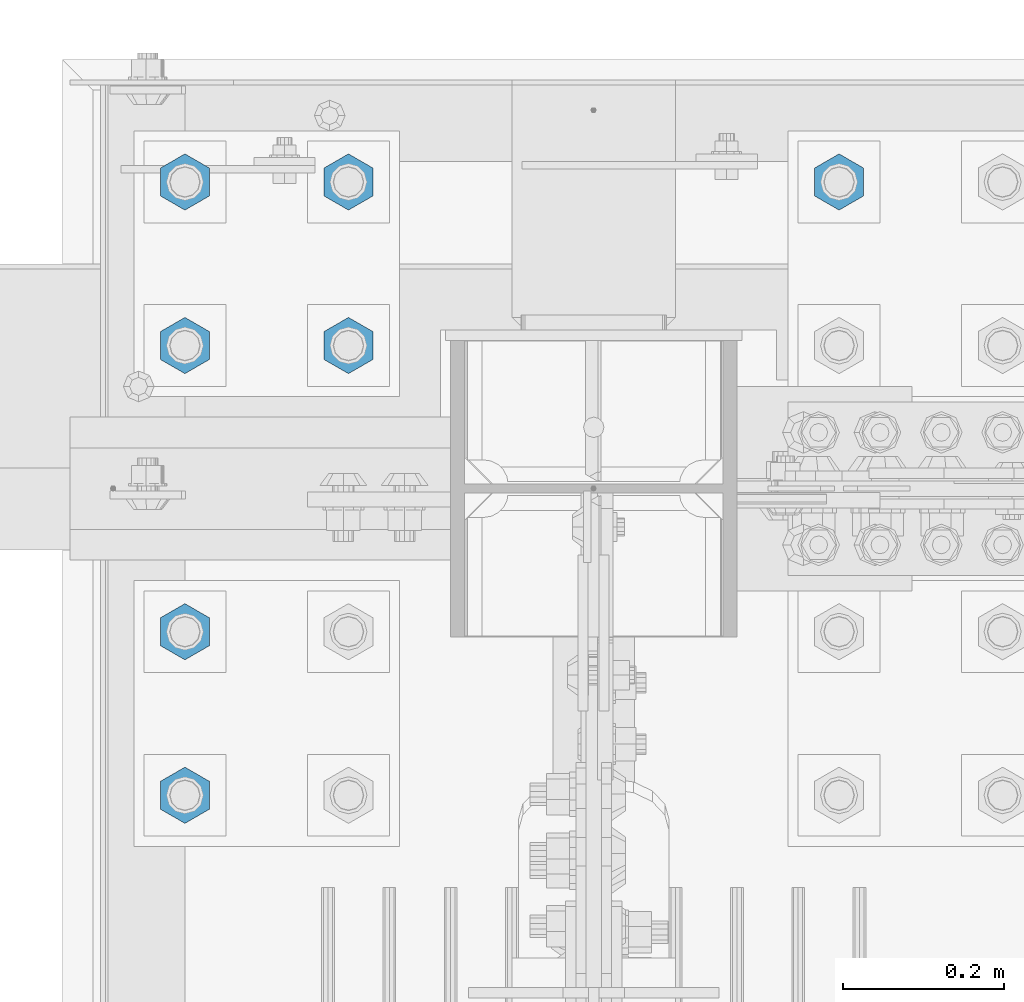
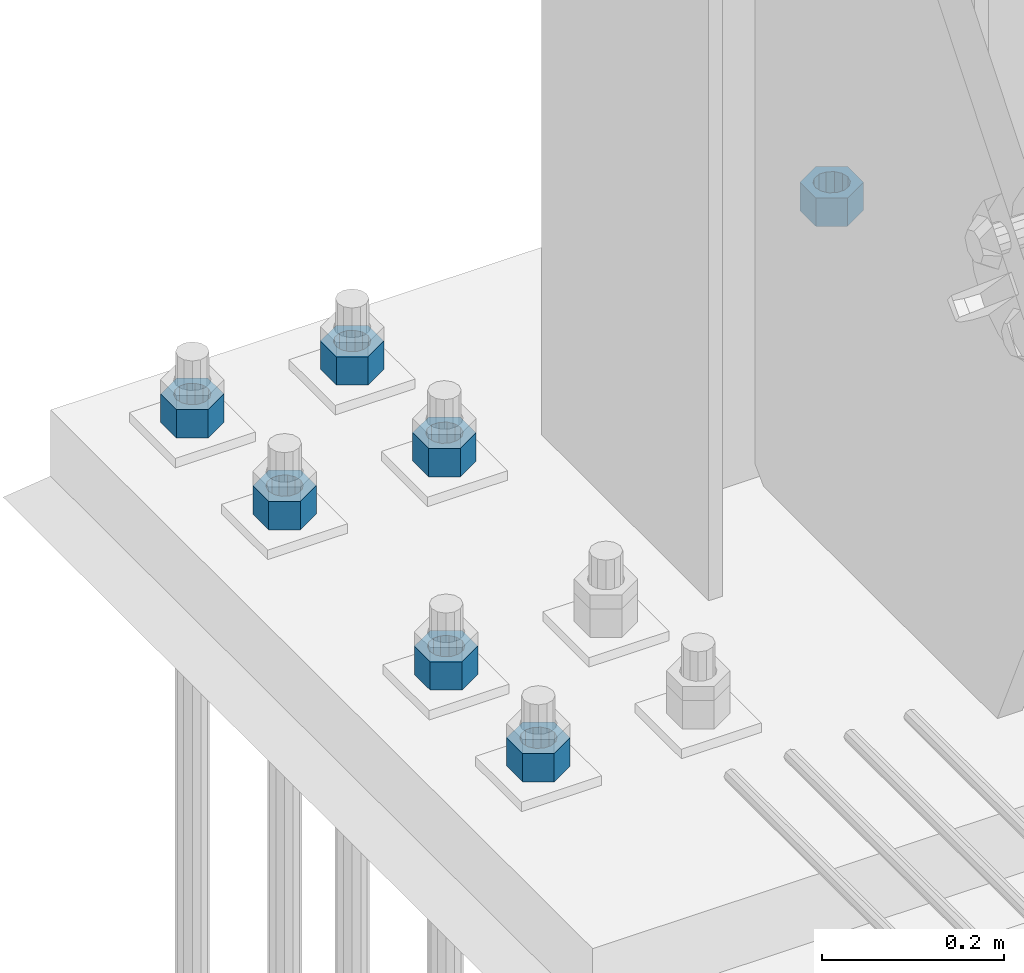
# One storey, part 1725 of 3843: 7 columns, 1 element without a shape of its own.
"""IFC2X3 building model written with IfcOpenShell, lengths in millimetres."""

from ifc_helpers import new_model, si_unit, frame, origin_with_axes, place, context, subcontext, project, spatial, faceted_brep, material, type_object, element, aggregate, save


model = new_model("IFC2X3")

# Units and contexts
model_context = context("Model", 3, precision=1e-05, world=origin_with_axes())
body_context = subcontext(model_context, "Body", "Model", "MODEL_VIEW")
ifc_project = project(units=[si_unit("LENGTHUNIT", "METRE", prefix="MILLI"), si_unit("AREAUNIT", "SQUARE_METRE"), si_unit("VOLUMEUNIT", "CUBIC_METRE"), si_unit("MASSUNIT", "GRAM", prefix="KILO"), si_unit("TIMEUNIT", "SECOND"), si_unit("PLANEANGLEUNIT", "RADIAN"), si_unit("SOLIDANGLEUNIT", "STERADIAN"), si_unit("THERMODYNAMICTEMPERATUREUNIT", "DEGREE_CELSIUS"), si_unit("LUMINOUSINTENSITYUNIT", "LUMEN")], contexts=[model_context])

# Site, building, storey
site_placement = place(None, origin_with_axes())
site = spatial("IfcSite", under=ifc_project, at=site_placement, CompositionType="ELEMENT")
building_placement = place(site_placement, origin_with_axes())
building = spatial("IfcBuilding", under=site, at=building_placement, Name="Undefined", CompositionType="ELEMENT")
storey_placement = place(building_placement, origin_with_axes())
storey = spatial("IfcBuildingStorey", under=building, at=storey_placement, Name="Undefined", CompositionType="ELEMENT", Elevation=0.0)

# Assembly, columns
assembly_placement = place(storey_placement, origin_with_axes())
assembly = element("IfcElementAssembly", 1, at=assembly_placement, inside=storey, Name="TEMPLATE", AssemblyPlace="NOTDEFINED", PredefinedType="RIGID_FRAME")
ifc_material = material(Name="STEEL/A572-50")
column_type = type_object("IfcColumnType", Name="1-1/2_HEAVY_HEX_NUT", PredefinedType="NOTDEFINED")
column_1_placement = place(assembly_placement, frame((77317.6, 104940.1, 29743.4), z_axis=(-1.0, 0.0, 0.0), x_axis=(0.0, 0.0, -1.0)))
column_1 = element("IfcColumn", 2, at=column_1_placement, type_object=column_type, material=ifc_material, Name="NUT", ObjectType="1-1/2_HEAVY_HEX_NUT", context=body_context, shape_type="Brep", body=[
    faceted_brep([(0.0, -34.9199981689453, 0.0), (0.0, -17.4599990844727, -30.25), (38.0999999999985, -17.4599990844727, -30.25), (38.0999999999985, -34.9199981689453, 0.0), (0.0, 17.4599990844727, -30.25), (38.0999999999985, 17.4599990844727, -30.25), (0.0, 34.9199981689453, 0.0), (38.0999999999985, 34.9199981689453, 0.0), (0.0, 17.4599990844727, 30.25), (38.0999999999985, 17.4599990844727, 30.25), (0.0, -17.4599990844727, 30.25), (38.0999999999985, -17.4599990844727, 30.25), (0.0, 0.0, 20.6399993896484), (0.0, 8.9553601105581, 18.5959968835959), (38.0999999999985, 8.9553601105581, 18.5959968835959), (38.0999999999985, 0.0, 20.6399993896484), (0.0, 16.1370013209525, 12.8688291298167), (38.0999999999985, 16.1370013209525, 12.8688291298167), (0.0, 20.1225115123816, 4.59283194104501), (38.0999999999985, 20.1225115123816, 4.59283194104501), (0.0, 20.1225115123816, -4.59283194104501), (38.0999999999985, 20.1225115123816, -4.59283194104501), (0.0, 16.1370013209525, -12.8688291298167), (38.0999999999985, 16.1370013209525, -12.8688291298167), (0.0, 8.9553601105581, -18.5959968835959), (38.0999999999985, 8.9553601105581, -18.5959968835959), (0.0, 0.0, -20.6399993896484), (38.0999999999985, 0.0, -20.6399993896484), (0.0, -8.9553601105581, -18.5959968835959), (38.0999999999985, -8.9553601105581, -18.5959968835959), (0.0, -16.1370013209525, -12.8688291298167), (38.0999999999985, -16.1370013209525, -12.8688291298167), (0.0, -20.1225115123816, -4.59283194104501), (38.0999999999985, -20.1225115123816, -4.59283194104501), (0.0, -20.1225115123816, 4.59283194104501), (38.0999999999985, -20.1225115123816, 4.59283194104501), (0.0, -16.1370013209525, 12.8688291298167), (38.0999999999985, -16.1370013209525, 12.8688291298167), (0.0, -8.9553601105581, 18.5959968835959), (38.0999999999985, -8.9553601105581, 18.5959968835959)], [[[0, 1, 2, 3]], [[1, 4, 5, 2]], [[4, 6, 7, 5]], [[6, 8, 9, 7]], [[8, 10, 11, 9]], [[10, 0, 3, 11]], [[12, 13, 14, 15]], [[13, 16, 17, 14]], [[16, 18, 19, 17]], [[18, 20, 21, 19]], [[20, 22, 23, 21]], [[22, 24, 25, 23]], [[24, 26, 27, 25]], [[26, 28, 29, 27]], [[28, 30, 31, 29]], [[30, 32, 33, 31]], [[32, 34, 35, 33]], [[34, 36, 37, 35]], [[36, 38, 39, 37]], [[38, 12, 15, 39]], [[5, 7, 9, 11, 3, 2], [17, 19, 21, 23, 25, 27, 29, 31, 33, 35, 37, 39, 15, 14]], [[10, 8, 6, 4, 1, 0], [38, 36, 34, 32, 30, 28, 26, 24, 22, 20, 18, 16, 13, 12]]]),
])
column_2_placement = place(assembly_placement, frame((76708.0, 104736.9, 29743.4), z_axis=(-1.0, 0.0, 0.0), x_axis=(0.0, 0.0, -1.0)))
column_2 = element("IfcColumn", 3, at=column_2_placement, type_object=column_type, material=ifc_material, Name="NUT", ObjectType="1-1/2_HEAVY_HEX_NUT", context=body_context, shape_type="Brep", body=[
    faceted_brep([(0.0, -34.9199981689453, 0.0), (0.0, -17.4599990844727, -30.25), (38.0999999999985, -17.4599990844727, -30.25), (38.0999999999985, -34.9199981689453, 0.0), (0.0, 17.4599990844727, -30.25), (38.0999999999985, 17.4599990844727, -30.25), (0.0, 34.9199981689453, 0.0), (38.0999999999985, 34.9199981689453, 0.0), (0.0, 17.4599990844727, 30.25), (38.0999999999985, 17.4599990844727, 30.25), (0.0, -17.4599990844727, 30.25), (38.0999999999985, -17.4599990844727, 30.25), (0.0, 0.0, 20.6399993896484), (0.0, 8.9553601105581, 18.5959968835959), (38.0999999999985, 8.9553601105581, 18.5959968835959), (38.0999999999985, 0.0, 20.6399993896484), (0.0, 16.1370013209525, 12.8688291298167), (38.0999999999985, 16.1370013209525, 12.8688291298167), (0.0, 20.1225115123816, 4.59283194104501), (38.0999999999985, 20.1225115123816, 4.59283194104501), (0.0, 20.1225115123816, -4.59283194104501), (38.0999999999985, 20.1225115123816, -4.59283194104501), (0.0, 16.1370013209525, -12.8688291298167), (38.0999999999985, 16.1370013209525, -12.8688291298167), (0.0, 8.9553601105581, -18.5959968835959), (38.0999999999985, 8.9553601105581, -18.5959968835959), (0.0, 0.0, -20.6399993896484), (38.0999999999985, 0.0, -20.6399993896484), (0.0, -8.9553601105581, -18.5959968835959), (38.0999999999985, -8.9553601105581, -18.5959968835959), (0.0, -16.1370013209525, -12.8688291298167), (38.0999999999985, -16.1370013209525, -12.8688291298167), (0.0, -20.1225115123816, -4.59283194104501), (38.0999999999985, -20.1225115123816, -4.59283194104501), (0.0, -20.1225115123816, 4.59283194104501), (38.0999999999985, -20.1225115123816, 4.59283194104501), (0.0, -16.1370013209525, 12.8688291298167), (38.0999999999985, -16.1370013209525, 12.8688291298167), (0.0, -8.9553601105581, 18.5959968835959), (38.0999999999985, -8.9553601105581, 18.5959968835959)], [[[0, 1, 2, 3]], [[1, 4, 5, 2]], [[4, 6, 7, 5]], [[6, 8, 9, 7]], [[8, 10, 11, 9]], [[10, 0, 3, 11]], [[12, 13, 14, 15]], [[13, 16, 17, 14]], [[16, 18, 19, 17]], [[18, 20, 21, 19]], [[20, 22, 23, 21]], [[22, 24, 25, 23]], [[24, 26, 27, 25]], [[26, 28, 29, 27]], [[28, 30, 31, 29]], [[30, 32, 33, 31]], [[32, 34, 35, 33]], [[34, 36, 37, 35]], [[36, 38, 39, 37]], [[38, 12, 15, 39]], [[5, 7, 9, 11, 3, 2], [17, 19, 21, 23, 25, 27, 29, 31, 33, 35, 37, 39, 15, 14]], [[10, 8, 6, 4, 1, 0], [38, 36, 34, 32, 30, 28, 26, 24, 22, 20, 18, 16, 13, 12]]]),
])
column_3_placement = place(assembly_placement, frame((76708.0, 104940.1, 29743.4), z_axis=(-1.0, 0.0, 0.0), x_axis=(0.0, 0.0, -1.0)))
column_3 = element("IfcColumn", 4, at=column_3_placement, type_object=column_type, material=ifc_material, Name="NUT", ObjectType="1-1/2_HEAVY_HEX_NUT", context=body_context, shape_type="Brep", body=[
    faceted_brep([(0.0, -34.9199981689453, 0.0), (0.0, -17.4599990844727, -30.25), (38.0999999999985, -17.4599990844727, -30.25), (38.0999999999985, -34.9199981689453, 0.0), (0.0, 17.4599990844727, -30.25), (38.0999999999985, 17.4599990844727, -30.25), (0.0, 34.9199981689453, 0.0), (38.0999999999985, 34.9199981689453, 0.0), (0.0, 17.4599990844727, 30.25), (38.0999999999985, 17.4599990844727, 30.25), (0.0, -17.4599990844727, 30.25), (38.0999999999985, -17.4599990844727, 30.25), (0.0, 0.0, 20.6399993896484), (0.0, 8.9553601105581, 18.5959968835959), (38.0999999999985, 8.9553601105581, 18.5959968835959), (38.0999999999985, 0.0, 20.6399993896484), (0.0, 16.1370013209525, 12.8688291298167), (38.0999999999985, 16.1370013209525, 12.8688291298167), (0.0, 20.1225115123816, 4.59283194104501), (38.0999999999985, 20.1225115123816, 4.59283194104501), (0.0, 20.1225115123816, -4.59283194104501), (38.0999999999985, 20.1225115123816, -4.59283194104501), (0.0, 16.1370013209525, -12.8688291298167), (38.0999999999985, 16.1370013209525, -12.8688291298167), (0.0, 8.9553601105581, -18.5959968835959), (38.0999999999985, 8.9553601105581, -18.5959968835959), (0.0, 0.0, -20.6399993896484), (38.0999999999985, 0.0, -20.6399993896484), (0.0, -8.9553601105581, -18.5959968835959), (38.0999999999985, -8.9553601105581, -18.5959968835959), (0.0, -16.1370013209525, -12.8688291298167), (38.0999999999985, -16.1370013209525, -12.8688291298167), (0.0, -20.1225115123816, -4.59283194104501), (38.0999999999985, -20.1225115123816, -4.59283194104501), (0.0, -20.1225115123816, 4.59283194104501), (38.0999999999985, -20.1225115123816, 4.59283194104501), (0.0, -16.1370013209525, 12.8688291298167), (38.0999999999985, -16.1370013209525, 12.8688291298167), (0.0, -8.9553601105581, 18.5959968835959), (38.0999999999985, -8.9553601105581, 18.5959968835959)], [[[0, 1, 2, 3]], [[1, 4, 5, 2]], [[4, 6, 7, 5]], [[6, 8, 9, 7]], [[8, 10, 11, 9]], [[10, 0, 3, 11]], [[12, 13, 14, 15]], [[13, 16, 17, 14]], [[16, 18, 19, 17]], [[18, 20, 21, 19]], [[20, 22, 23, 21]], [[22, 24, 25, 23]], [[24, 26, 27, 25]], [[26, 28, 29, 27]], [[28, 30, 31, 29]], [[30, 32, 33, 31]], [[32, 34, 35, 33]], [[34, 36, 37, 35]], [[36, 38, 39, 37]], [[38, 12, 15, 39]], [[5, 7, 9, 11, 3, 2], [17, 19, 21, 23, 25, 27, 29, 31, 33, 35, 37, 39, 15, 14]], [[10, 8, 6, 4, 1, 0], [38, 36, 34, 32, 30, 28, 26, 24, 22, 20, 18, 16, 13, 12]]]),
])
column_4_placement = place(assembly_placement, frame((76504.8, 104178.1, 29743.4), z_axis=(1.0, 0.0, 0.0), x_axis=(0.0, 0.0, -1.0)))
column_4 = element("IfcColumn", 5, at=column_4_placement, type_object=column_type, material=ifc_material, Name="NUT", ObjectType="1-1/2_HEAVY_HEX_NUT", context=body_context, shape_type="Brep", body=[
    faceted_brep([(0.0, -34.9199981689453, 0.0), (0.0, -17.4599990844727, -30.25), (38.0999999999985, -17.4599990844727, -30.25), (38.0999999999985, -34.9199981689453, 0.0), (0.0, 17.4599990844727, -30.25), (38.0999999999985, 17.4599990844727, -30.25), (0.0, 34.9199981689453, 0.0), (38.0999999999985, 34.9199981689453, 0.0), (0.0, 17.4599990844727, 30.25), (38.0999999999985, 17.4599990844727, 30.25), (0.0, -17.4599990844727, 30.25), (38.0999999999985, -17.4599990844727, 30.25), (0.0, 0.0, 20.6399993896484), (0.0, 8.9553601105581, 18.5959968835959), (38.0999999999985, 8.9553601105581, 18.5959968835959), (38.0999999999985, 0.0, 20.6399993896484), (0.0, 16.1370013209525, 12.8688291298167), (38.0999999999985, 16.1370013209525, 12.8688291298167), (0.0, 20.1225115123816, 4.59283194104501), (38.0999999999985, 20.1225115123816, 4.59283194104501), (0.0, 20.1225115123816, -4.59283194104501), (38.0999999999985, 20.1225115123816, -4.59283194104501), (0.0, 16.1370013209525, -12.8688291298167), (38.0999999999985, 16.1370013209525, -12.8688291298167), (0.0, 8.9553601105581, -18.5959968835959), (38.0999999999985, 8.9553601105581, -18.5959968835959), (0.0, 0.0, -20.6399993896484), (38.0999999999985, 0.0, -20.6399993896484), (0.0, -8.9553601105581, -18.5959968835959), (38.0999999999985, -8.9553601105581, -18.5959968835959), (0.0, -16.1370013209525, -12.8688291298167), (38.0999999999985, -16.1370013209525, -12.8688291298167), (0.0, -20.1225115123816, -4.59283194104501), (38.0999999999985, -20.1225115123816, -4.59283194104501), (0.0, -20.1225115123816, 4.59283194104501), (38.0999999999985, -20.1225115123816, 4.59283194104501), (0.0, -16.1370013209525, 12.8688291298167), (38.0999999999985, -16.1370013209525, 12.8688291298167), (0.0, -8.9553601105581, 18.5959968835959), (38.0999999999985, -8.9553601105581, 18.5959968835959)], [[[0, 1, 2, 3]], [[1, 4, 5, 2]], [[4, 6, 7, 5]], [[6, 8, 9, 7]], [[8, 10, 11, 9]], [[10, 0, 3, 11]], [[12, 13, 14, 15]], [[13, 16, 17, 14]], [[16, 18, 19, 17]], [[18, 20, 21, 19]], [[20, 22, 23, 21]], [[22, 24, 25, 23]], [[24, 26, 27, 25]], [[26, 28, 29, 27]], [[28, 30, 31, 29]], [[30, 32, 33, 31]], [[32, 34, 35, 33]], [[34, 36, 37, 35]], [[36, 38, 39, 37]], [[38, 12, 15, 39]], [[5, 7, 9, 11, 3, 2], [17, 19, 21, 23, 25, 27, 29, 31, 33, 35, 37, 39, 15, 14]], [[10, 8, 6, 4, 1, 0], [38, 36, 34, 32, 30, 28, 26, 24, 22, 20, 18, 16, 13, 12]]]),
])
column_5_placement = place(assembly_placement, frame((76504.8, 104381.3, 29743.4), z_axis=(1.0, 0.0, 0.0), x_axis=(0.0, 0.0, -1.0)))
column_5 = element("IfcColumn", 6, at=column_5_placement, type_object=column_type, material=ifc_material, Name="NUT", ObjectType="1-1/2_HEAVY_HEX_NUT", context=body_context, shape_type="Brep", body=[
    faceted_brep([(0.0, -34.9199981689453, 0.0), (0.0, -17.4599990844727, -30.25), (38.0999999999985, -17.4599990844727, -30.25), (38.0999999999985, -34.9199981689453, 0.0), (0.0, 17.4599990844727, -30.25), (38.0999999999985, 17.4599990844727, -30.25), (0.0, 34.9199981689453, 0.0), (38.0999999999985, 34.9199981689453, 0.0), (0.0, 17.4599990844727, 30.25), (38.0999999999985, 17.4599990844727, 30.25), (0.0, -17.4599990844727, 30.25), (38.0999999999985, -17.4599990844727, 30.25), (0.0, 0.0, 20.6399993896484), (0.0, 8.9553601105581, 18.5959968835959), (38.0999999999985, 8.9553601105581, 18.5959968835959), (38.0999999999985, 0.0, 20.6399993896484), (0.0, 16.1370013209525, 12.8688291298167), (38.0999999999985, 16.1370013209525, 12.8688291298167), (0.0, 20.1225115123816, 4.59283194104501), (38.0999999999985, 20.1225115123816, 4.59283194104501), (0.0, 20.1225115123816, -4.59283194104501), (38.0999999999985, 20.1225115123816, -4.59283194104501), (0.0, 16.1370013209525, -12.8688291298167), (38.0999999999985, 16.1370013209525, -12.8688291298167), (0.0, 8.9553601105581, -18.5959968835959), (38.0999999999985, 8.9553601105581, -18.5959968835959), (0.0, 0.0, -20.6399993896484), (38.0999999999985, 0.0, -20.6399993896484), (0.0, -8.9553601105581, -18.5959968835959), (38.0999999999985, -8.9553601105581, -18.5959968835959), (0.0, -16.1370013209525, -12.8688291298167), (38.0999999999985, -16.1370013209525, -12.8688291298167), (0.0, -20.1225115123816, -4.59283194104501), (38.0999999999985, -20.1225115123816, -4.59283194104501), (0.0, -20.1225115123816, 4.59283194104501), (38.0999999999985, -20.1225115123816, 4.59283194104501), (0.0, -16.1370013209525, 12.8688291298167), (38.0999999999985, -16.1370013209525, 12.8688291298167), (0.0, -8.9553601105581, 18.5959968835959), (38.0999999999985, -8.9553601105581, 18.5959968835959)], [[[0, 1, 2, 3]], [[1, 4, 5, 2]], [[4, 6, 7, 5]], [[6, 8, 9, 7]], [[8, 10, 11, 9]], [[10, 0, 3, 11]], [[12, 13, 14, 15]], [[13, 16, 17, 14]], [[16, 18, 19, 17]], [[18, 20, 21, 19]], [[20, 22, 23, 21]], [[22, 24, 25, 23]], [[24, 26, 27, 25]], [[26, 28, 29, 27]], [[28, 30, 31, 29]], [[30, 32, 33, 31]], [[32, 34, 35, 33]], [[34, 36, 37, 35]], [[36, 38, 39, 37]], [[38, 12, 15, 39]], [[5, 7, 9, 11, 3, 2], [17, 19, 21, 23, 25, 27, 29, 31, 33, 35, 37, 39, 15, 14]], [[10, 8, 6, 4, 1, 0], [38, 36, 34, 32, 30, 28, 26, 24, 22, 20, 18, 16, 13, 12]]]),
])
column_6_placement = place(assembly_placement, frame((76504.8, 104736.9, 29743.4), z_axis=(-1.0, 0.0, 0.0), x_axis=(0.0, 0.0, -1.0)))
column_6 = element("IfcColumn", 7, at=column_6_placement, type_object=column_type, material=ifc_material, Name="NUT", ObjectType="1-1/2_HEAVY_HEX_NUT", context=body_context, shape_type="Brep", body=[
    faceted_brep([(0.0, -34.9199981689453, 0.0), (0.0, -17.4599990844727, -30.25), (38.0999999999985, -17.4599990844727, -30.25), (38.0999999999985, -34.9199981689453, 0.0), (0.0, 17.4599990844727, -30.25), (38.0999999999985, 17.4599990844727, -30.25), (0.0, 34.9199981689453, 0.0), (38.0999999999985, 34.9199981689453, 0.0), (0.0, 17.4599990844727, 30.25), (38.0999999999985, 17.4599990844727, 30.25), (0.0, -17.4599990844727, 30.25), (38.0999999999985, -17.4599990844727, 30.25), (0.0, 0.0, 20.6399993896484), (0.0, 8.9553601105581, 18.5959968835959), (38.0999999999985, 8.9553601105581, 18.5959968835959), (38.0999999999985, 0.0, 20.6399993896484), (0.0, 16.1370013209525, 12.8688291298167), (38.0999999999985, 16.1370013209525, 12.8688291298167), (0.0, 20.1225115123816, 4.59283194104501), (38.0999999999985, 20.1225115123816, 4.59283194104501), (0.0, 20.1225115123816, -4.59283194104501), (38.0999999999985, 20.1225115123816, -4.59283194104501), (0.0, 16.1370013209525, -12.8688291298167), (38.0999999999985, 16.1370013209525, -12.8688291298167), (0.0, 8.9553601105581, -18.5959968835959), (38.0999999999985, 8.9553601105581, -18.5959968835959), (0.0, 0.0, -20.6399993896484), (38.0999999999985, 0.0, -20.6399993896484), (0.0, -8.9553601105581, -18.5959968835959), (38.0999999999985, -8.9553601105581, -18.5959968835959), (0.0, -16.1370013209525, -12.8688291298167), (38.0999999999985, -16.1370013209525, -12.8688291298167), (0.0, -20.1225115123816, -4.59283194104501), (38.0999999999985, -20.1225115123816, -4.59283194104501), (0.0, -20.1225115123816, 4.59283194104501), (38.0999999999985, -20.1225115123816, 4.59283194104501), (0.0, -16.1370013209525, 12.8688291298167), (38.0999999999985, -16.1370013209525, 12.8688291298167), (0.0, -8.9553601105581, 18.5959968835959), (38.0999999999985, -8.9553601105581, 18.5959968835959)], [[[0, 1, 2, 3]], [[1, 4, 5, 2]], [[4, 6, 7, 5]], [[6, 8, 9, 7]], [[8, 10, 11, 9]], [[10, 0, 3, 11]], [[12, 13, 14, 15]], [[13, 16, 17, 14]], [[16, 18, 19, 17]], [[18, 20, 21, 19]], [[20, 22, 23, 21]], [[22, 24, 25, 23]], [[24, 26, 27, 25]], [[26, 28, 29, 27]], [[28, 30, 31, 29]], [[30, 32, 33, 31]], [[32, 34, 35, 33]], [[34, 36, 37, 35]], [[36, 38, 39, 37]], [[38, 12, 15, 39]], [[5, 7, 9, 11, 3, 2], [17, 19, 21, 23, 25, 27, 29, 31, 33, 35, 37, 39, 15, 14]], [[10, 8, 6, 4, 1, 0], [38, 36, 34, 32, 30, 28, 26, 24, 22, 20, 18, 16, 13, 12]]]),
])
column_7_placement = place(assembly_placement, frame((76504.8, 104940.1, 29743.4), z_axis=(-1.0, 0.0, 0.0), x_axis=(0.0, 0.0, -1.0)))
column_7 = element("IfcColumn", 8, at=column_7_placement, type_object=column_type, material=ifc_material, Name="NUT", ObjectType="1-1/2_HEAVY_HEX_NUT", context=body_context, shape_type="Brep", body=[
    faceted_brep([(0.0, -34.9199981689453, 0.0), (0.0, -17.4599990844727, -30.25), (38.0999999999985, -17.4599990844727, -30.25), (38.0999999999985, -34.9199981689453, 0.0), (0.0, 17.4599990844727, -30.25), (38.0999999999985, 17.4599990844727, -30.25), (0.0, 34.9199981689453, 0.0), (38.0999999999985, 34.9199981689453, 0.0), (0.0, 17.4599990844727, 30.25), (38.0999999999985, 17.4599990844727, 30.25), (0.0, -17.4599990844727, 30.25), (38.0999999999985, -17.4599990844727, 30.25), (0.0, 0.0, 20.6399993896484), (0.0, 8.9553601105581, 18.5959968835959), (38.0999999999985, 8.9553601105581, 18.5959968835959), (38.0999999999985, 0.0, 20.6399993896484), (0.0, 16.1370013209525, 12.8688291298167), (38.0999999999985, 16.1370013209525, 12.8688291298167), (0.0, 20.1225115123816, 4.59283194104501), (38.0999999999985, 20.1225115123816, 4.59283194104501), (0.0, 20.1225115123816, -4.59283194104501), (38.0999999999985, 20.1225115123816, -4.59283194104501), (0.0, 16.1370013209525, -12.8688291298167), (38.0999999999985, 16.1370013209525, -12.8688291298167), (0.0, 8.9553601105581, -18.5959968835959), (38.0999999999985, 8.9553601105581, -18.5959968835959), (0.0, 0.0, -20.6399993896484), (38.0999999999985, 0.0, -20.6399993896484), (0.0, -8.9553601105581, -18.5959968835959), (38.0999999999985, -8.9553601105581, -18.5959968835959), (0.0, -16.1370013209525, -12.8688291298167), (38.0999999999985, -16.1370013209525, -12.8688291298167), (0.0, -20.1225115123816, -4.59283194104501), (38.0999999999985, -20.1225115123816, -4.59283194104501), (0.0, -20.1225115123816, 4.59283194104501), (38.0999999999985, -20.1225115123816, 4.59283194104501), (0.0, -16.1370013209525, 12.8688291298167), (38.0999999999985, -16.1370013209525, 12.8688291298167), (0.0, -8.9553601105581, 18.5959968835959), (38.0999999999985, -8.9553601105581, 18.5959968835959)], [[[0, 1, 2, 3]], [[1, 4, 5, 2]], [[4, 6, 7, 5]], [[6, 8, 9, 7]], [[8, 10, 11, 9]], [[10, 0, 3, 11]], [[12, 13, 14, 15]], [[13, 16, 17, 14]], [[16, 18, 19, 17]], [[18, 20, 21, 19]], [[20, 22, 23, 21]], [[22, 24, 25, 23]], [[24, 26, 27, 25]], [[26, 28, 29, 27]], [[28, 30, 31, 29]], [[30, 32, 33, 31]], [[32, 34, 35, 33]], [[34, 36, 37, 35]], [[36, 38, 39, 37]], [[38, 12, 15, 39]], [[5, 7, 9, 11, 3, 2], [17, 19, 21, 23, 25, 27, 29, 31, 33, 35, 37, 39, 15, 14]], [[10, 8, 6, 4, 1, 0], [38, 36, 34, 32, 30, 28, 26, 24, 22, 20, 18, 16, 13, 12]]]),
])
aggregate(assembly, [column_1, column_2, column_3, column_4, column_5, column_6, column_7])

save(model, "model.ifc")
